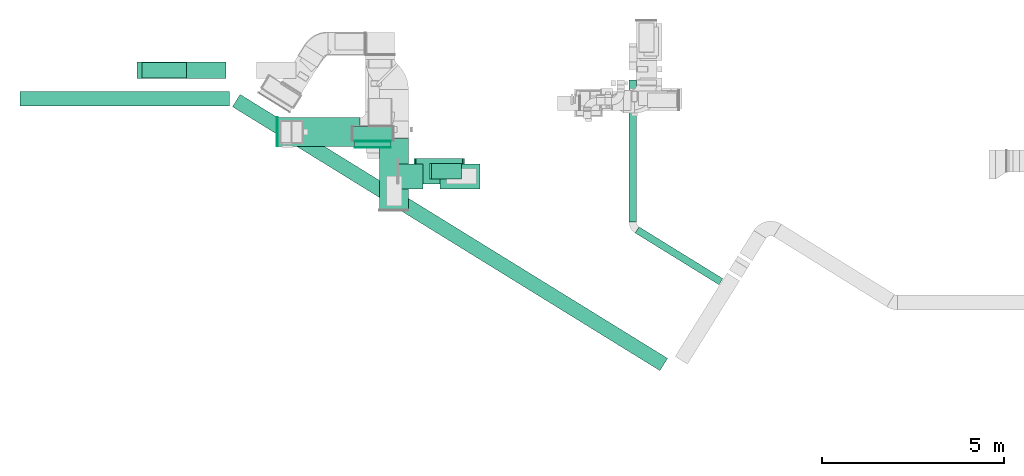
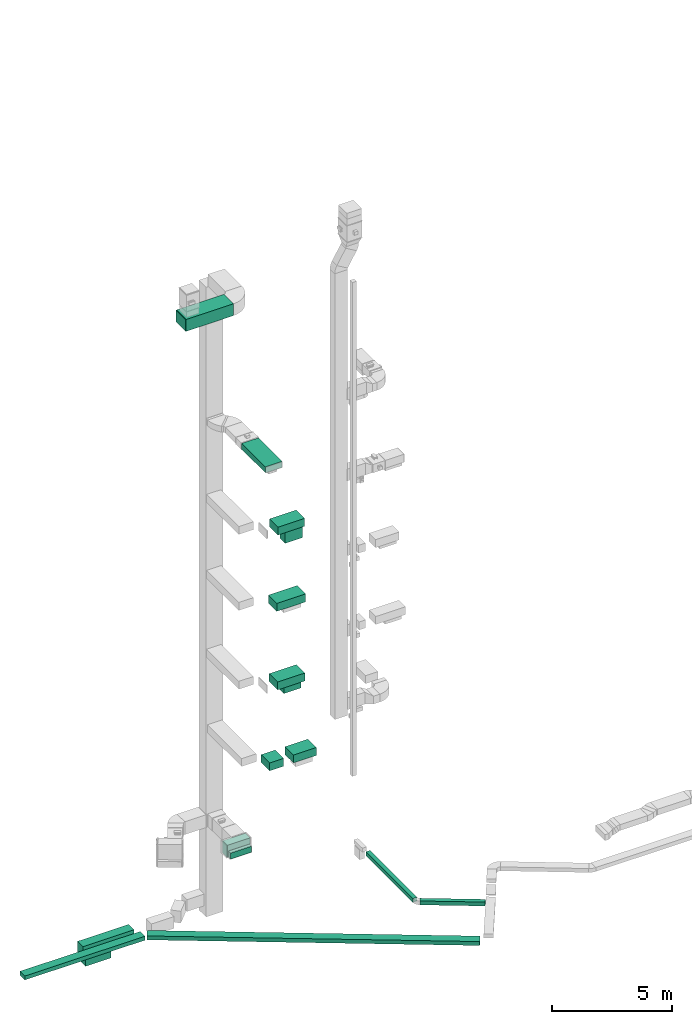
# One storey, part 5 of 29: 17 flow segments, 2 flow fittings, 1 flow terminal.
"""IFC2X3 building model written with IfcOpenShell, lengths in millimetres."""

from ifc_helpers import new_model, entity, si_unit, converted_unit, derived_unit, direction, frame, frame_2d, origin, origin_2d_with_axis, place, context, subcontext, project, spatial, rectangle, extrude, source, transform, mapped, material, type_object, type_shapes, element, save


model = new_model("IFC2X3")

# Units and contexts
model_context = context("Model", 3, precision=0.01, world=origin(), true_north=direction((6.12303176911189e-17, 1.0)))
body_context = subcontext(model_context, "Body", "Model", "MODEL_VIEW")
ifc_project = project(units=[si_unit("LENGTHUNIT", "METRE", prefix="MILLI"), si_unit("AREAUNIT", "SQUARE_METRE"), si_unit("VOLUMEUNIT", "CUBIC_METRE"), converted_unit("PLANEANGLEUNIT", "DEGREE", entity("IfcRatioMeasure", 0.0174532925199433), si_unit("PLANEANGLEUNIT", "RADIAN"), dimensions=[0, 0, 0, 0, 0, 0, 0]), si_unit("MASSUNIT", "GRAM", prefix="KILO"), derived_unit("MASSDENSITYUNIT", [(si_unit("MASSUNIT", "GRAM", prefix="KILO"), 1), (si_unit("LENGTHUNIT", "METRE"), -3)]), derived_unit("MOMENTOFINERTIAUNIT", [(si_unit("LENGTHUNIT", "METRE"), 4)]), si_unit("TIMEUNIT", "SECOND"), si_unit("FREQUENCYUNIT", "HERTZ"), si_unit("THERMODYNAMICTEMPERATUREUNIT", "DEGREE_CELSIUS"), derived_unit("THERMALTRANSMITTANCEUNIT", [(si_unit("MASSUNIT", "GRAM", prefix="KILO"), 1), (si_unit("THERMODYNAMICTEMPERATUREUNIT", "KELVIN"), -1), (si_unit("TIMEUNIT", "SECOND"), -3)]), derived_unit("VOLUMETRICFLOWRATEUNIT", [(si_unit("LENGTHUNIT", "METRE"), 3), (si_unit("TIMEUNIT", "SECOND"), -1)]), derived_unit("MASSFLOWRATEUNIT", [(si_unit("MASSUNIT", "GRAM", prefix="KILO"), 1), (si_unit("TIMEUNIT", "SECOND"), -1)]), derived_unit("ROTATIONALFREQUENCYUNIT", [(si_unit("TIMEUNIT", "SECOND"), -1)]), si_unit("ELECTRICCURRENTUNIT", "AMPERE"), si_unit("ELECTRICVOLTAGEUNIT", "VOLT"), si_unit("POWERUNIT", "WATT"), si_unit("FORCEUNIT", "NEWTON", prefix="KILO"), si_unit("ILLUMINANCEUNIT", "LUX"), si_unit("LUMINOUSFLUXUNIT", "LUMEN"), si_unit("LUMINOUSINTENSITYUNIT", "CANDELA"), derived_unit("USERDEFINED", [(si_unit("MASSUNIT", "GRAM", prefix="KILO"), -1), (si_unit("LENGTHUNIT", "METRE"), -2), (si_unit("TIMEUNIT", "SECOND"), 3), (si_unit("LUMINOUSFLUXUNIT", "LUMEN"), 1)]), derived_unit("LINEARVELOCITYUNIT", [(si_unit("LENGTHUNIT", "METRE"), 1), (si_unit("TIMEUNIT", "SECOND"), -1)]), si_unit("PRESSUREUNIT", "PASCAL"), derived_unit("USERDEFINED", [(si_unit("LENGTHUNIT", "METRE"), -2), (si_unit("MASSUNIT", "GRAM", prefix="KILO"), 1), (si_unit("TIMEUNIT", "SECOND"), -2)]), derived_unit("LINEARFORCEUNIT", [(si_unit("MASSUNIT", "GRAM", prefix="KILO"), 1), (si_unit("LENGTHUNIT", "METRE"), 1), (si_unit("TIMEUNIT", "SECOND"), -2), (si_unit("LENGTHUNIT", "METRE"), -1)]), derived_unit("PLANARFORCEUNIT", [(si_unit("MASSUNIT", "GRAM", prefix="KILO"), 1), (si_unit("LENGTHUNIT", "METRE"), 1), (si_unit("TIMEUNIT", "SECOND"), -2), (si_unit("LENGTHUNIT", "METRE"), -2)])], contexts=[model_context])

# Site, building, storey
site_placement = place(None, frame((0.0, -0.00077364408347762, 0.0)))
site = spatial("IfcSite", under=ifc_project, at=site_placement, CompositionType="ELEMENT")
building_placement = place(site_placement, origin())
building = spatial("IfcBuilding", under=site, at=building_placement, CompositionType="ELEMENT")
storey_placement = place(building_placement, origin())
storey = spatial("IfcBuildingStorey", under=building, at=storey_placement, CompositionType="ELEMENT", Elevation=0.0)

# Flow segments
duct_segment_type_1 = type_object("IfcDuctSegmentType", PredefinedType="NOTDEFINED")
flow_segment_1_placement = place(storey_placement, frame((-5375.43166880308, 14592.0644899786, -1099.99875340398)))
element("IfcFlowSegment", 1, at=flow_segment_1_placement, inside=storey, type_object=duct_segment_type_1, context=body_context, shape_type="SweptSolid", body=[
    extrude(rectangle(XDim=5771.90420210275, YDim=400.0, at=frame_2d((0.0, 1.09423581307055e-12), x_axis=(1.0, 0.0))), frame((2885.95210105137, 200.0, 0.0)), (0.0, 0.0, 1.0), 200.0),
])
flow_segment_2_placement = place(storey_placement, frame((11565.8994492503, 9667.01705295091, -1100.0)))
element("IfcFlowSegment", 2, at=flow_segment_2_placement, inside=storey, type_object=duct_segment_type_1, context=body_context, shape_type="SweptSolid", body=[
    extrude(rectangle(XDim=2711.86979617274, YDim=199.999999999998, at=frame_2d((2.38742359215394e-12, 2.34479102800833e-13), x_axis=(1.0, 0.0))), frame((1206.15849942139, 797.64461663067, 0.0), z_axis=(0.0, 0.0, 1.0), x_axis=(0.850783354162399, -0.525516588016189, 0.0)), (0.0, 0.0, 1.0), 200.0),
])
flow_segment_3_placement = place(storey_placement, frame((3785.84688819858, 13632.5, 2500.0)))
element("IfcFlowSegment", 3, at=flow_segment_3_placement, inside=storey, type_object=duct_segment_type_1, context=body_context, shape_type="SweptSolid", body=[
    extrude(rectangle(XDim=1100.0, YDim=400.0, at=origin_2d_with_axis()), frame((550.0, 200.0, 0.0)), (0.0, 0.0, 1.0), 600.0),
])
flow_segment_4_placement = place(storey_placement, frame((5049.45036991614, 12300.4683688133, 7250.0)))
element("IfcFlowSegment", 4, at=flow_segment_4_placement, inside=storey, type_object=duct_segment_type_1, context=body_context, shape_type="SweptSolid", body=[
    extrude(rectangle(XDim=665.48850074056, YDim=699.999999999999, at=frame_2d((0.0, -1.08002495835535e-12), x_axis=(1.0, 0.0))), frame((332.74425037028, 350.0, 0.0), z_axis=(0.0, 0.0, 1.0), x_axis=(-1.0, 0.0, 0.0)), (0.0, 0.0, 1.0), 400.0),
])
flow_segment_5_placement = place(storey_placement, frame((475.274625781649, 7302.46275823647, -1100.0)))
element("IfcFlowSegment", 5, at=flow_segment_5_placement, inside=storey, type_object=duct_segment_type_1, context=body_context, shape_type="SweptSolid", body=[
    extrude(rectangle(XDim=13833.2016747026, YDim=400.000000000002, at=frame_2d((4.54747350886464e-13, -1.90425453183707e-12), x_axis=(1.0, 0.0))), frame((5990.32147376956, 3803.79504057749, 0.0), z_axis=(0.0, 0.0, 1.0), x_axis=(0.850887908023427, -0.525347283213224, 0.0)), (0.0, 0.0, 1.0), 200.0),
])
flow_segment_6_placement = place(storey_placement, frame((11399.830255056, 11389.9237893366, -1100.0)))
element("IfcFlowSegment", 6, at=flow_segment_6_placement, inside=storey, type_object=duct_segment_type_1, context=body_context, shape_type="SweptSolid", body=[
    extrude(rectangle(XDim=3910.05184285594, YDim=200.0, at=origin_2d_with_axis()), frame((100.0, 1955.02592142797, 0.0), z_axis=(0.0, 0.0, 1.0), x_axis=(0.0, 1.0, 0.0)), (0.0, 0.0, 1.0), 200.0),
])

# Flow fitting
ifc_material_1 = material()
duct_fitting_type_1 = type_object("IfcDuctFittingType", PredefinedType="NOTDEFINED", material=ifc_material_1)
shared_shape_1 = source(origin(), body_context, "Body", "SweptSolid", [
    extrude(rectangle(XDim=24.9999999999999, YDim=800.0, at=frame_2d((-3.32178728967847e-13, 5.6843418860808e-14), x_axis=(1.0, 0.0))), frame((12.5000000000059, 0.0, -300.0)), (0.0, 0.0, 1.0), 600.0),
])
type_shapes(duct_fitting_type_1, [shared_shape_1])
flow_fitting_1_placement = place(storey_placement, frame((1723.3305169552, 13877.5681314502, 30300.0), z_axis=(0.0, 0.0, 1.0), x_axis=(-1.0, 0.0, 0.0)))
element("IfcFlowFitting", 7, at=flow_fitting_1_placement, inside=storey, type_object=duct_fitting_type_1, material=ifc_material_1, context=body_context, shape_type="MappedRepresentation", body=[
    mapped(shared_shape_1, transform((0.0, 0.0, 0.0), scale=1.0)),
])

# Flow segments
duct_segment_type_2 = type_object("IfcDuctSegmentType", PredefinedType="NOTDEFINED")
flow_segment_7_placement = place(storey_placement, frame((5959.68731985035, 12587.1581969188, 18300.0)))
element("IfcFlowSegment", 8, at=flow_segment_7_placement, inside=storey, type_object=duct_segment_type_2, context=body_context, shape_type="SweptSolid", body=[
    extrude(rectangle(XDim=825.0, YDim=425.000000000001, at=frame_2d((5.40012479177676e-13, -1.08002495835535e-12), x_axis=(1.0, 0.0))), frame((412.500000000002, 212.500000000002, 0.0), z_axis=(0.0, 0.0, 1.0), x_axis=(-1.0, 0.0, 0.0)), (0.0, 0.0, 1.0), 629.999999999982),
])
flow_segment_8_placement = place(storey_placement, frame((1723.33051695519, 13477.5681314502, 30000.0)))
element("IfcFlowSegment", 9, at=flow_segment_8_placement, inside=storey, type_object=duct_segment_type_2, context=body_context, shape_type="SweptSolid", body=[
    extrude(rectangle(XDim=2270.00000000001, YDim=800.0, at=frame_2d((0.0, 1.10844666778576e-12), x_axis=(1.0, 0.0))), frame((1135.0, 400.0, 0.0), z_axis=(0.0, 0.0, 1.0), x_axis=(-1.0, 0.0, 0.0)), (0.0, 0.0, 1.0), 600.000000000002),
])
flow_segment_9_placement = place(storey_placement, frame((4519.66175990127, 11729.5346231923, 22900.0)))
element("IfcFlowSegment", 10, at=flow_segment_9_placement, inside=storey, type_object=duct_segment_type_2, context=body_context, shape_type="SweptSolid", body=[
    extrude(rectangle(XDim=1972.07412336472, YDim=800.0, at=origin_2d_with_axis()), frame((400.0, 986.037061682358, 0.0), z_axis=(0.0, 0.0, 1.0), x_axis=(0.0, -1.0, 0.0)), (0.0, 0.0, 1.0), 300.000000000001),
])
flow_segment_10_placement = place(storey_placement, frame((5529.64840161908, 12449.6581969188, 18950.0)))
element("IfcFlowSegment", 11, at=flow_segment_10_placement, inside=storey, type_object=duct_segment_type_2, context=body_context, shape_type="SweptSolid", body=[
    extrude(rectangle(XDim=1282.07783646253, YDim=700.000000000001, at=origin_2d_with_axis()), frame((641.038918231265, 350.0, 0.0)), (0.0, 0.0, 1.0), 400.0),
])
flow_segment_11_placement = place(storey_placement, frame((5480.45036991614, 12449.6581969188, 15100.0)))
element("IfcFlowSegment", 12, at=flow_segment_11_placement, inside=storey, type_object=duct_segment_type_2, context=body_context, shape_type="SweptSolid", body=[
    extrude(rectangle(XDim=1381.27586816547, YDim=699.999999999999, at=frame_2d((0.0, 1.08002495835535e-12), x_axis=(1.0, 0.0))), frame((690.637934082735, 350.0, 0.0)), (0.0, 0.0, 1.0), 400.0),
])
flow_segment_12_placement = place(storey_placement, frame((5519.64840161908, 12449.6581969188, 11100.0)))
element("IfcFlowSegment", 13, at=flow_segment_12_placement, inside=storey, type_object=duct_segment_type_2, context=body_context, shape_type="SweptSolid", body=[
    extrude(rectangle(XDim=1310.0, YDim=699.999999999999, at=origin_2d_with_axis()), frame((655.0, 350.0, 0.0)), (0.0, 0.0, 1.0), 400.0),
])
flow_segment_13_placement = place(storey_placement, frame((5894.8831788235, 12587.1581969188, 10700.0)))
element("IfcFlowSegment", 14, at=flow_segment_13_placement, inside=storey, type_object=duct_segment_type_2, context=body_context, shape_type="SweptSolid", body=[
    extrude(rectangle(XDim=825.0, YDim=425.000000000001, at=frame_2d((5.40012479177676e-13, -1.08002495835535e-12), x_axis=(1.0, 0.0))), frame((412.5, 212.500000000004, 0.0), z_axis=(0.0, 0.0, 1.0), x_axis=(-1.0, 0.0, 0.0)), (0.0, 0.0, 1.0), 379.999999999992),
])
flow_segment_14_placement = place(storey_placement, frame((3838.73846384665, 13450.1017206743, 2500.0)))
element("IfcFlowSegment", 15, at=flow_segment_14_placement, inside=storey, type_object=duct_segment_type_2, context=body_context, shape_type="SweptSolid", body=[
    extrude(rectangle(XDim=162.39827932573, YDim=1000.0, at=frame_2d((-1.08713038571295e-12, -2.55795384873636e-13), x_axis=(1.0, 0.0))), frame((500.0, 81.1991396628746, 0.0), z_axis=(0.0, 0.0, 1.0), x_axis=(0.0, 1.0, 0.0)), (0.0, 0.0, 1.0), 300.0),
])
flow_segment_15_placement = place(storey_placement, frame((-2154.56438170037, 15350.1020645575, -1600.0)))
element("IfcFlowSegment", 16, at=flow_segment_15_placement, inside=storey, type_object=duct_segment_type_2, context=body_context, shape_type="SweptSolid", body=[
    extrude(rectangle(XDim=2454.67069149708, YDim=449.999999999999, at=origin_2d_with_axis()), frame((1227.33534574854, 225.0, 0.0), z_axis=(0.0, 0.0, 1.0), x_axis=(-1.0, 0.0, 0.0)), (0.0, 0.0, 1.0), 600.0),
])
flow_segment_16_placement = place(storey_placement, frame((-2012.49999999991, 15362.6020645575, -2050.0)))
element("IfcFlowSegment", 17, at=flow_segment_16_placement, inside=storey, type_object=duct_segment_type_2, context=body_context, shape_type="SweptSolid", body=[
    extrude(rectangle(XDim=1225.0, YDim=425.000000000001, at=frame_2d((0.0, 1.08002495835535e-12), x_axis=(1.0, 0.0))), frame((612.500000000002, 212.500000000008, 0.0), z_axis=(0.0, 0.0, 1.0), x_axis=(-1.0, 0.0, 0.0)), (0.0, 0.0, 1.0), 430.0),
])
flow_segment_17_placement = place(storey_placement, frame((6194.9388706567, 12300.4683688133, 7250.0)))
element("IfcFlowSegment", 18, at=flow_segment_17_placement, inside=storey, type_object=duct_segment_type_2, context=body_context, shape_type="SweptSolid", body=[
    extrude(rectangle(XDim=1094.22665279493, YDim=699.999999999999, at=frame_2d((0.0, -1.08002495835535e-12), x_axis=(1.0, 0.0))), frame((547.113326397465, 350.0, 0.0), z_axis=(0.0, 0.0, 1.0), x_axis=(-1.0, 0.0, 0.0)), (0.0, 0.0, 1.0), 400.0),
])

# Flow terminal
ifc_material_2 = material()
air_terminal_type = type_object("IfcAirTerminalType", PredefinedType="NOTDEFINED", material=ifc_material_2)
shared_shape_2 = source(origin(), body_context, "Body", "SweptSolid", [
    extrude(rectangle(XDim=4.0, YDim=999.999999999999, at=origin_2d_with_axis()), frame((0.0, -2.0, -150.0), z_axis=(0.0, 0.0, 1.0), x_axis=(0.0, 1.0, 0.0)), (0.0, 0.0, 1.0), 300.000000000005),
])
type_shapes(air_terminal_type, [shared_shape_2])
flow_terminal_placement = place(storey_placement, frame((4338.73846384665, 13450.1017206743, 2650.0)))
element("IfcFlowTerminal", 19, at=flow_terminal_placement, inside=storey, type_object=air_terminal_type, material=ifc_material_2, context=body_context, shape_type="MappedRepresentation", body=[
    mapped(shared_shape_2, transform((0.0, 0.0, 0.0), scale=1.0)),
])

# Flow fitting
duct_fitting_type_2 = type_object("IfcDuctFittingType", PredefinedType="NOTDEFINED", material=ifc_material_1)
shared_shape_3 = source(origin(), body_context, "Body", "SweptSolid", [
    extrude(rectangle(XDim=26.0960000000015, YDim=1000.0, at=frame_2d((-7.7715611723761e-13, -5.6843418860808e-14), x_axis=(1.0, 0.0))), frame((6.95199999999999, 0.0, -150.0)), (0.0, 0.0, 1.0), 300.0),
])
type_shapes(duct_fitting_type_2, [shared_shape_3])
flow_fitting_2_placement = place(storey_placement, frame((4338.73846384665, 13632.5, 2650.0), z_axis=(0.0, 0.0, -1.0), x_axis=(0.0, -1.0, 0.0)))
element("IfcFlowFitting", 20, at=flow_fitting_2_placement, inside=storey, type_object=duct_fitting_type_2, material=ifc_material_1, context=body_context, shape_type="MappedRepresentation", body=[
    mapped(shared_shape_3, transform((0.0, 0.0, 0.0), scale=1.0)),
])

save(model, "model.ifc")
